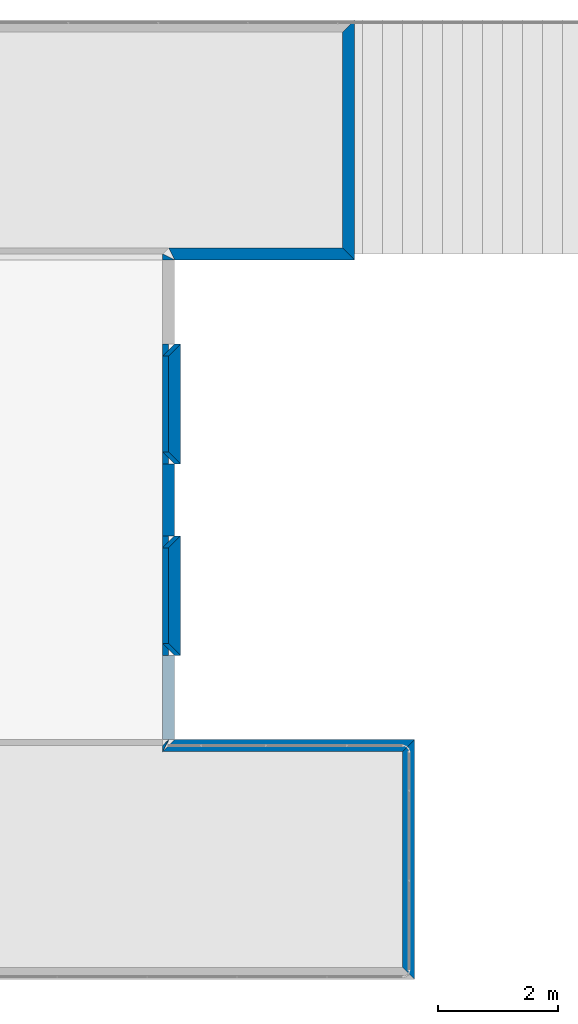
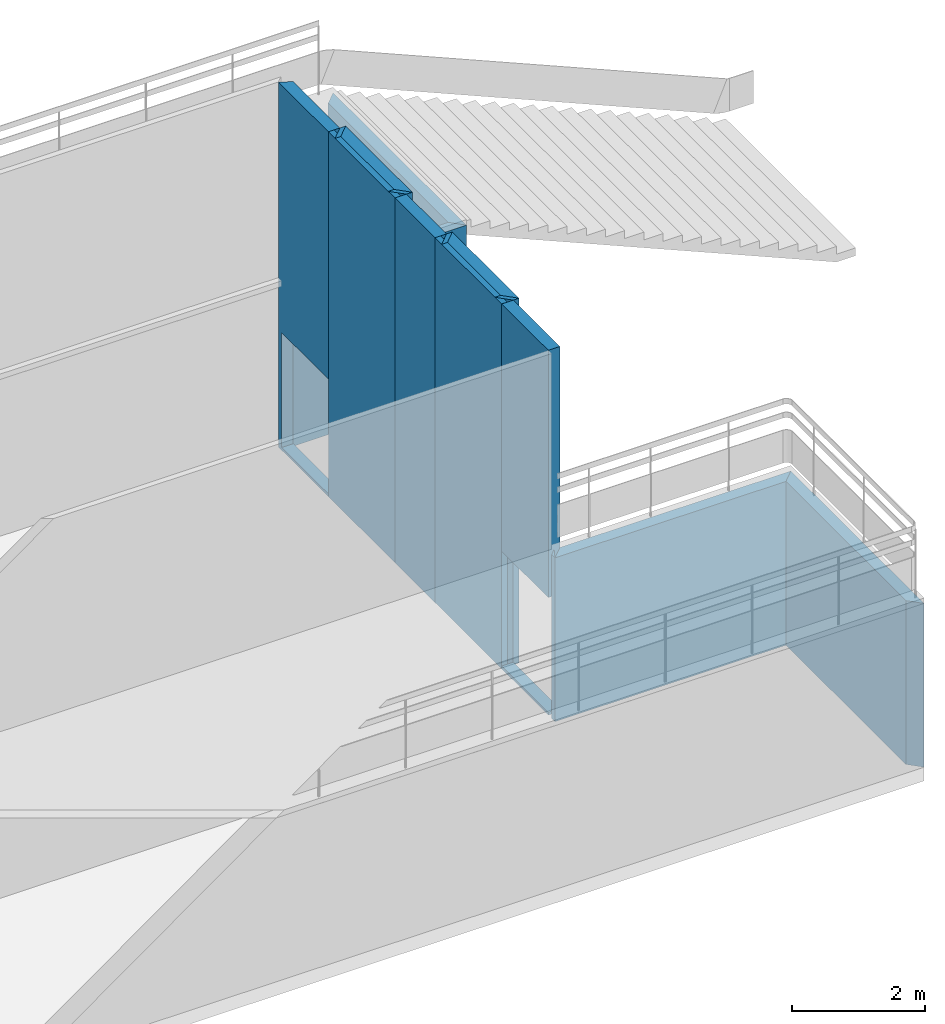
# One storey, part 2 of 54: 16 walls, 2 openings.
"""IFC2X3 building model written with IfcOpenShell, lengths in metres."""

from ifc_helpers import new_model, entity, si_unit, converted_unit, derived_unit, frame, origin_with_axes, place, context, project, spatial, polyline, outline, extrude, material, layer, layer_set, layer_usage, element, save


model = new_model("IFC2X3")

# Units and contexts
context_of_model_1 = context(None, 3, world=origin_with_axes())
context_of_model_2 = context(None, 3, world=origin_with_axes())
context_of_model_3 = context(None, 2, world=origin_with_axes())
context_of_model_4 = context(None, 3, world=origin_with_axes())
ifc_project = project(units=[si_unit("LENGTHUNIT", "METRE"), si_unit("AREAUNIT", "SQUARE_METRE"), si_unit("ELECTRICCURRENTUNIT", "AMPERE"), si_unit("ELECTRICVOLTAGEUNIT", "VOLT"), si_unit("ELECTRICRESISTANCEUNIT", "OHM"), si_unit("POWERUNIT", "WATT"), si_unit("MASSUNIT", "GRAM"), si_unit("SOLIDANGLEUNIT", "STERADIAN"), si_unit("THERMODYNAMICTEMPERATUREUNIT", "KELVIN"), si_unit("PRESSUREUNIT", "PASCAL"), si_unit("LUMINOUSFLUXUNIT", "LUMEN"), si_unit("ILLUMINANCEUNIT", "LUX"), si_unit("FREQUENCYUNIT", "HERTZ"), si_unit("VOLUMEUNIT", "CUBIC_METRE"), si_unit("TIMEUNIT", "SECOND"), derived_unit("VOLUMETRICFLOWRATEUNIT", [(si_unit("TIMEUNIT", "SECOND"), -1), (si_unit("VOLUMEUNIT", "CUBIC_METRE"), 1)]), derived_unit("THERMALTRANSMITTANCEUNIT", [(si_unit("AREAUNIT", "SQUARE_METRE"), -1), (si_unit("THERMODYNAMICTEMPERATUREUNIT", "KELVIN"), -1), (si_unit("POWERUNIT", "WATT"), 1)]), converted_unit("PLANEANGLEUNIT", "DEGREE", entity("IfcPlaneAngleMeasure", 57.29577951308232), si_unit("PLANEANGLEUNIT", "RADIAN"), dimensions=[0, 0, 0, 0, 0, 0, 0])], contexts=[context_of_model_1, context_of_model_2, context_of_model_3, context_of_model_4])

# Site, building, storey
site = spatial("IfcSite", under=ifc_project, CompositionType="ELEMENT")
building_placement = place(None, origin_with_axes())
building = spatial("IfcBuilding", under=site, at=building_placement, Name="Tower", CompositionType="ELEMENT")
storey_placement = place(building_placement, frame((0.0, 0.0, 72.0), z_axis=(0.0, 0.0, 1.0), x_axis=(1.0, 0.0, 0.0)))
storey = spatial("IfcBuildingStorey", under=building, at=storey_placement, Name="Level 1", CompositionType="ELEMENT", Elevation=72.0)

# Walls
ifc_material_1 = material(Name="Layer-Yttervegg 20.0cm")
ifc_layer_1 = layer(ifc_material_1, 0.2000000029802322, ventilated=False)
ifc_layer_set_1 = layer_set([ifc_layer_1], Name="ML-Yttervegg 20.0cm - 0.200")
ifc_layer_usage_1 = layer_usage(ifc_layer_set_1, "AXIS2", "POSITIVE", 0.0)
wall_1_placement = place(storey_placement, frame((0.0, 1.399999976158142, 0.0), z_axis=(0.0, 0.0, 1.0), x_axis=(1.0, 0.0, 0.0)))
element("IfcWallStandardCase", 1, at=wall_1_placement, inside=storey, material=ifc_layer_usage_1, Name="Yttervegg 20.0cm", context=context_of_model_1, shape_type="SweptSolid", body=[
    extrude(outline(polyline([(0.0, 0.0), (0.1000000014901161, 0.0), (-0.1000000014901161, 0.2000000476837158), (-0.2000000029802322, 0.2000000476837158), (0.0, 0.0)])), origin_with_axes(), (0.0, 0.0, 1.0), 6.680000007152557),
])
wall_2_placement = place(storey_placement, frame((0.1000000014901161, 1.399999976158142, 0.0), z_axis=(0.0, 0.0, 1.0), x_axis=(-4.371138828673793e-08, 1.0, 0.0)))
element("IfcWallStandardCase", 2, at=wall_2_placement, inside=storey, material=ifc_layer_usage_1, Name="Yttervegg 20.0cm", context=context_of_model_1, shape_type="SweptSolid", body=[
    extrude(outline(polyline([(0.0, 0.0), (2.00000011920929, 0.0), (1.800000071525574, 0.2000000029802322), (0.2000000476837157, 0.2000000029802322), (0.0, 0.0)])), frame((0.0, 0.0, 0.0), z_axis=(0.0, 0.0, 1.0), x_axis=(0.9999999999999989, -4.371138999732807e-08, 0.0)), (0.0, 0.0, 1.0), 6.680000007152557),
])
wall_3_placement = place(storey_placement, frame((0.1000000014901161, 3.400000095367432, 0.0), z_axis=(0.0, 0.0, 1.0), x_axis=(-1.0, -8.742277657347586e-08, 0.0)))
element("IfcWallStandardCase", 3, at=wall_3_placement, inside=storey, material=ifc_layer_usage_1, Name="Yttervegg 20.0cm", context=context_of_model_1, shape_type="SweptSolid", body=[
    extrude(outline(polyline([(0.0, 0.0), (0.1000000014901162, 0.0), (0.3000000193715098, 0.2000000476837157), (0.2000000029802325, 0.2000000476837157), (0.0, 0.0)])), frame((0.0, 0.0, 0.0), z_axis=(0.0, 0.0, 1.0), x_axis=(0.9999999999999961, -8.742277882348861e-08, 0.0)), (0.0, 0.0, 1.0), 6.680000007152557),
])
wall_4_placement = place(storey_placement, frame((0.0, 4.599999904632568, 0.0), z_axis=(0.0, 0.0, 1.0), x_axis=(1.0, 0.0, 0.0)))
element("IfcWallStandardCase", 4, at=wall_4_placement, inside=storey, material=ifc_layer_usage_1, Name="Yttervegg 20.0cm", context=context_of_model_1, shape_type="SweptSolid", body=[
    extrude(outline(polyline([(0.0, 0.0), (0.1000000014901161, 0.0), (-0.1000000014901161, 0.1999998092651367), (-0.2000000029802322, 0.1999998092651367), (0.0, 0.0)])), origin_with_axes(), (0.0, 0.0, 1.0), 6.680000007152557),
])
wall_5_placement = place(storey_placement, frame((0.1000000014901161, 4.599999904632568, 0.0), z_axis=(0.0, 0.0, 1.0), x_axis=(-4.371138828673793e-08, 1.0, 0.0)))
element("IfcWallStandardCase", 5, at=wall_5_placement, inside=storey, material=ifc_layer_usage_1, Name="Yttervegg 20.0cm", context=context_of_model_1, shape_type="SweptSolid", body=[
    extrude(outline(polyline([(0.0, 0.0), (2.000000476837158, 0.0), (1.800000667572021, 0.2000000029802323), (0.1999998092651368, 0.2000000029802323), (0.0, 0.0)])), frame((0.0, 0.0, 0.0), z_axis=(0.0, 0.0, 1.0), x_axis=(0.9999999999999991, -4.371139000125587e-08, 0.0)), (0.0, 0.0, 1.0), 6.680000007152557),
])
wall_6_placement = place(storey_placement, frame((0.1000000014901161, 6.600000381469727, 0.0), z_axis=(0.0, 0.0, 1.0), x_axis=(-1.0, -8.742277657347586e-08, 0.0)))
element("IfcWallStandardCase", 6, at=wall_6_placement, inside=storey, material=ifc_layer_usage_1, Name="Yttervegg 20.0cm", context=context_of_model_1, shape_type="SweptSolid", body=[
    extrude(outline(polyline([(0.0, 0.0), (0.1000000014901162, 0.0), (0.3000000193715098, 0.1999998092651362), (0.2000000029802325, 0.1999998092651366), (0.0, 0.0)])), frame((0.0, 0.0, 0.0), z_axis=(0.0, 0.0, 1.0), x_axis=(0.9999999999999961, -8.742277882348861e-08, 0.0)), (0.0, 0.0, 1.0), 6.680000007152557),
])

# Wall, opening
wall_7_placement = place(storey_placement, frame((0.0, 0.0, 0.0), z_axis=(0.0, 0.0, 1.0), x_axis=(-4.371138828673793e-08, 1.0, 0.0)))
wall_7 = element("IfcWallStandardCase", 7, at=wall_7_placement, inside=storey, material=ifc_layer_usage_1, Name="Yttervegg 20.0cm", context=context_of_model_1, shape_type="SweptSolid", body=[
    extrude(outline(polyline([(0.0, 0.0), (1.399999976158142, 0.0), (1.399999976158142, 0.2000001966953278), (6.408534727192494e-14, 0.2000002413988114), (0.0, 0.0)])), frame((0.0, 0.0, 0.0), z_axis=(0.0, 0.0, 1.0), x_axis=(0.999999999999999, -4.371139000186241e-08, 0.0)), (0.0, 0.0, 1.0), 6.680000007152557),
])
opening_1_placement = place(wall_7_placement, frame((8.742352637597342e-09, 0.2000002413988112, 0.05000000074505806), z_axis=(0.0, 0.0, 1.0), x_axis=(1.0, 0.0, 0.0)))
element("IfcOpeningElement", 8, at=opening_1_placement, cuts=wall_7, context=context_of_model_1, shape_type="SweptSolid", body=[
    extrude(outline(polyline([(0.0, 0.0), (2.099999904632568, 0.0), (2.099999904632568, 1.399999976158079), (0.0, 1.399999976158079), (0.0, 0.0)])), frame((0.0, 0.0, 0.0), z_axis=(1.768694444263233e-07, 0.9999999999999845, 0.0), x_axis=(0.0, 0.0, 1.0)), (0.0, 1.768694444263233e-07, -0.9999999999999843), 0.2),
])

# Walls
ifc_material_2 = material()
ifc_layer_2 = layer(ifc_material_2, 0.1, ventilated=False)
ifc_layer_set_2 = layer_set([ifc_layer_2])
ifc_layer_usage_2 = layer_usage(ifc_layer_set_2, "AXIS2", "POSITIVE", 0.0)
wall_8_placement = place(storey_placement, frame((-0.1000001952052116, 1.399999976158142, 0.0), z_axis=(0.0, 0.0, 1.0), x_axis=(7.549790126404332e-08, 1.0, 0.0)))
element("IfcWallStandardCase", 9, at=wall_8_placement, inside=storey, material=ifc_layer_usage_2, context=context_of_model_1, shape_type="SweptSolid", body=[
    extrude(outline(polyline([(0.0, 0.0), (2.00000011920929, 0.0), (2.000000116229058, 0.1000000014901161), (-2.980231942056554e-09, 0.1000000014901161), (0.0, 0.0)])), frame((0.0, 0.0, 0.0), z_axis=(0.0, 0.0, 1.0), x_axis=(0.9999999999999991, 4.56955789421146e-08, 0.0)), (0.0, 0.0, 1.0), 6.680000007152557),
])
wall_9_placement = place(storey_placement, frame((0.0, 3.400000095367432, 0.0), z_axis=(0.0, 0.0, 1.0), x_axis=(-4.371138828673793e-08, 1.0, 0.0)))
element("IfcWallStandardCase", 10, at=wall_9_placement, inside=storey, material=ifc_layer_usage_1, Name="Yttervegg 20.0cm", context=context_of_model_1, shape_type="SweptSolid", body=[
    extrude(outline(polyline([(0.0, 0.0), (1.199999809265137, 0.0), (1.199999809265137, 0.2000001072883606), (-2.070181031287583e-16, 0.200000137090683), (0.0, 0.0)])), frame((0.0, 0.0, 0.0), z_axis=(0.0, 0.0, 1.0), x_axis=(0.9999999999999991, -4.371139000186239e-08, 0.0)), (0.0, 0.0, 1.0), 6.680000007152557),
])
wall_10_placement = place(storey_placement, frame((-0.1000001057982445, 4.599999904632568, 0.0), z_axis=(0.0, 0.0, 1.0), x_axis=(7.549790126404332e-08, 1.0, 0.0)))
element("IfcWallStandardCase", 11, at=wall_10_placement, inside=storey, material=ifc_layer_usage_2, context=context_of_model_1, shape_type="SweptSolid", body=[
    extrude(outline(polyline([(0.0, 0.0), (2.000000476837159, 0.0), (2.000000473856928, 0.1000000014901161), (-2.980231631587041e-09, 0.1000000014901161), (0.0, 0.0)])), frame((0.0, 0.0, 0.0), z_axis=(0.0, 0.0, 1.0), x_axis=(0.9999999999999991, 4.569558426725571e-08, 0.0)), (0.0, 0.0, 1.0), 6.680000007152557),
])

# Wall, opening
wall_11_placement = place(storey_placement, frame((0.0, 6.600000381469727, 0.0), z_axis=(0.0, 0.0, 1.0), x_axis=(-4.371138828673793e-08, 1.0, 0.0)))
wall_11 = element("IfcWallStandardCase", 12, at=wall_11_placement, inside=storey, material=ifc_layer_usage_1, Name="Yttervegg 20.0cm", context=context_of_model_1, shape_type="SweptSolid", body=[
    extrude(outline(polyline([(0.0, 0.0), (1.399999618530273, 0.0), (1.499999046325682, 0.2000000178813935), (-2.957181873358956e-16, 0.2000000476837159), (0.0, 0.0)])), frame((0.0, 0.0, 0.0), z_axis=(0.0, 0.0, 1.0), x_axis=(0.999999999999999, -4.371139000186241e-08, 0.0)), (0.0, 0.0, 1.0), 6.680000007152557),
])
opening_2_placement = place(wall_11_placement, frame((8.742279788975793e-09, 0.2000000476837156, 0.05000000074505806), z_axis=(0.0, 0.0, 1.0), x_axis=(1.0, 0.0, 0.0)))
element("IfcOpeningElement", 13, at=opening_2_placement, cuts=wall_11, context=context_of_model_1, shape_type="SweptSolid", body=[
    extrude(outline(polyline([(0.0, 0.0), (2.099999904632568, 0.0), (2.099999904632568, 1.399999499320916), (0.0, 1.399999499320916), (0.0, 0.0)])), frame((0.0, 0.0, 0.0), z_axis=(4.371139007308417e-08, 0.9999999999999991, 0.0), x_axis=(0.0, 0.0, 1.0)), (0.0, 4.371139007308417e-08, -0.999999999999999), 0.2),
])

# Walls
wall_12_placement = place(storey_placement, frame((4.0, -4.0, 0.0), z_axis=(0.0, 0.0, 1.0), x_axis=(-4.371138828673793e-08, 1.0, 0.0)))
element("IfcWallStandardCase", 14, at=wall_12_placement, inside=storey, material=ifc_layer_usage_1, Name="Yttervegg 20.0cm", context=context_of_model_1, shape_type="SweptSolid", body=[
    extrude(outline(polyline([(0.0, 0.0), (4.0, 0.0), (3.799999997019767, 0.2000000476837159), (0.2000000476837157, 0.2000000476837163), (0.0, 0.0)])), frame((0.0, 0.0, 0.0), z_axis=(0.0, 0.0, 1.0), x_axis=(0.9999999999999991, -4.371138995207247e-08, 0.0)), (0.0, 0.0, 1.0), 3.0),
])
wall_13_placement = place(storey_placement, frame((4.0, 0.0, 0.0), z_axis=(0.0, 0.0, 1.0), x_axis=(-1.0, -8.742277657347586e-08, 0.0)))
element("IfcWallStandardCase", 15, at=wall_13_placement, inside=storey, material=ifc_layer_usage_1, Name="Yttervegg 20.0cm", context=context_of_model_1, shape_type="SweptSolid", body=[
    extrude(outline(polyline([(0.0, 0.0), (4.0, 0.0), (4.200000002980232, 0.2000000029802323), (0.2000000476837159, 0.2000000029802323), (0.0, 0.0)])), frame((0.0, 0.0, 0.0), z_axis=(0.0, 0.0, 1.0), x_axis=(0.9999999999999962, -8.742278000372475e-08, 0.0)), (0.0, 0.0, 1.0), 3.0),
])
wall_14_placement = place(storey_placement, frame((-0.1000000983476639, 0.0, 0.0), z_axis=(0.0, 0.0, 1.0), x_axis=(1.0, 0.0, 0.0)))
element("IfcWallStandardCase", 16, at=wall_14_placement, inside=storey, material=ifc_layer_usage_2, context=context_of_model_1, shape_type="SweptSolid", body=[
    extrude(outline(polyline([(0.0, 0.0), (-7.375694917443572e-08, 7.375702061367611e-08), (0.1414212898560397, 0.0), (0.2121320032726884, 0.07071064492798668), (0.0, 0.0)])), frame((0.0, 0.0, 0.0), z_axis=(0.0, 0.0, 1.0), x_axis=(-0.7071064387431597, -0.7071071236297695, 0.0)), (0.0, 0.0, 1.0), 3.000000000745058),
])
wall_15_placement = place(storey_placement, frame((0.0, 8.0, 0.0), z_axis=(0.0, 0.0, 1.0), x_axis=(1.0, 0.0, 0.0)))
element("IfcWallStandardCase", 17, at=wall_15_placement, inside=storey, material=ifc_layer_usage_1, Name="Yttervegg 20.0cm", context=context_of_model_1, shape_type="SweptSolid", body=[
    extrude(outline(polyline([(0.0, 0.0), (3.0, 0.0), (2.799999952316284, 0.1999998092651367), (-0.1000003814697266, 0.1999998092651367), (0.0, 0.0)])), origin_with_axes(), (0.0, 0.0, 1.0), 3.0),
])
wall_16_placement = place(storey_placement, frame((3.0, 8.0, 0.0), z_axis=(0.0, 0.0, 1.0), x_axis=(-4.371138828673793e-08, 1.0, 0.0)))
element("IfcWallStandardCase", 18, at=wall_16_placement, inside=storey, material=ifc_layer_usage_1, Name="Yttervegg 20.0cm", context=context_of_model_1, shape_type="SweptSolid", body=[
    extrude(outline(polyline([(0.0, 0.0), (3.999999999999999, 0.0), (3.800000190734862, 0.2000000476837155), (0.1999998092651357, 0.2000000476837157), (0.0, 0.0)])), frame((0.0, 0.0, 0.0), z_axis=(0.0, 0.0, 1.0), x_axis=(0.9999999999999991, -4.371138995207247e-08, 0.0)), (0.0, 0.0, 1.0), 3.0),
])

save(model, "model.ifc")
